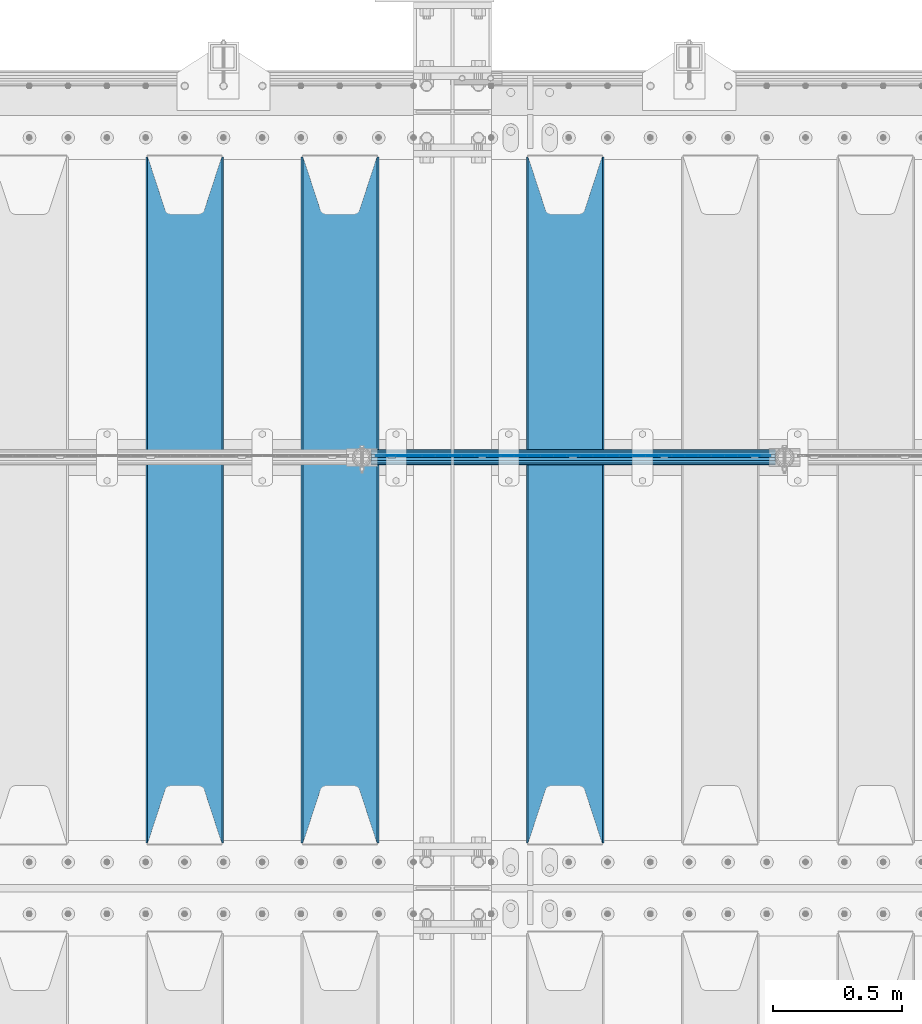
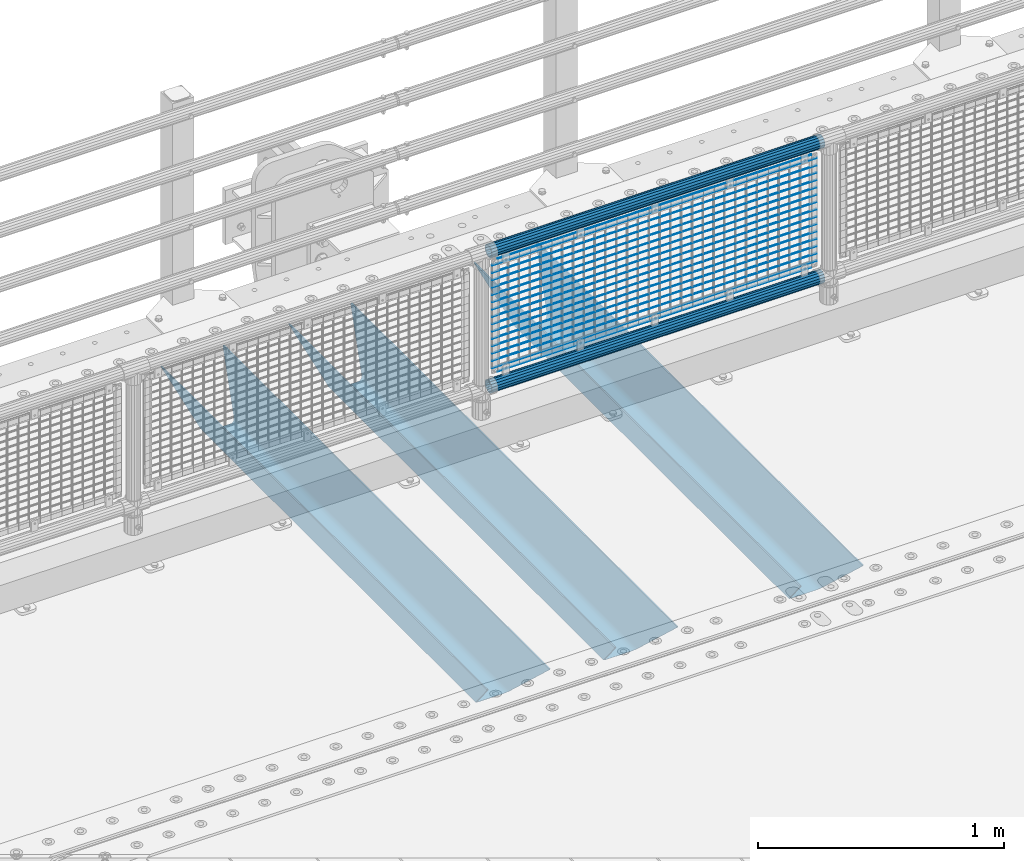
# One storey, part 137 of 270: 22 beams.
"""IFC2X3 building model written with IfcOpenShell, lengths in millimetres."""

import ifcopenshell
import ifcopenshell.guid

model = None  # the IFC model being written
_history = None  # IfcOwnerHistory: only IFC2X3 demands one
_inside = {}  # id of a spatial element -> (the spatial element, [elements in it])
_under = {}  # id of a project, library or spatial element -> (it, [spatial elements below it])
_declared = {}  # id of a project -> (the project, [libraries it declares])
_typed = {}  # id of a type object -> (the type object, [elements of that type])
_made_of = {}  # id of a material, layer set ... -> (it, [elements and type objects made of it])


def new_model(schema):
    """Start an empty IFC model of exactly this schema.

    Asked for "IFC4X3", IfcOpenShell would pick the latest addendum, in which some entities
    have other attributes; the version numbers below select the first issue.
    IFC2X3 requires an IfcOwnerHistory on every rooted entity: one is made here for all.
    """
    global model, _history
    if schema == "IFC4X3":
        model = ifcopenshell.file(schema_version=(4, 3, 0, 0))
    else:
        model = ifcopenshell.file(schema=schema)
    _inside.clear()
    _under.clear()
    _declared.clear()
    _typed.clear()
    _made_of.clear()
    _history = None
    if model.schema == "IFC2X3":
        org = make("IfcOrganization", Name="unknown")
        user = make(
            "IfcPersonAndOrganization",
            ThePerson=make("IfcPerson", FamilyName="unknown"),
            TheOrganization=org,
        )
        app = make(
            "IfcApplication",
            ApplicationDeveloper=org,
            Version="unknown",
            ApplicationFullName="unknown",
            ApplicationIdentifier="unknown",
        )
        _history = make(
            "IfcOwnerHistory",
            OwningUser=user,
            OwningApplication=app,
            ChangeAction="ADDED",
            CreationDate=0,
        )
    return model


def make(cls, **values):
    """One entity of the class cls with the attributes given. An attribute that is None is left unset."""
    return model.create_entity(
        cls, **{name: value for name, value in values.items() if value is not None}
    )


def rooted(cls, **values):
    """An entity with a GlobalId (a new one), such as an element, a storey or a relation."""
    return make(cls, GlobalId=ifcopenshell.guid.new(), OwnerHistory=_history, **values)


def si_unit(unit_type, name, prefix=None):
    """IfcSIUnit, for example si_unit("LENGTHUNIT", "METRE", prefix="MILLI")."""
    return make("IfcSIUnit", UnitType=unit_type, Prefix=prefix, Name=name)


def assignment(units):
    """IfcUnitAssignment: the units of a project."""
    return None if units is None else make("IfcUnitAssignment", Units=units)


def point(xyz):
    """IfcCartesianPoint."""
    return None if xyz is None else make("IfcCartesianPoint", Coordinates=xyz)


def direction(xyz):
    """IfcDirection."""
    return None if xyz is None else make("IfcDirection", DirectionRatios=xyz)


def frame(location, z_axis=None, x_axis=None):
    """IfcAxis2Placement3D, a coordinate frame: its origin and axes. An axis left out is left unset."""
    return make(
        "IfcAxis2Placement3D",
        Location=point(location),
        Axis=direction(z_axis),
        RefDirection=direction(x_axis),
    )


def origin_with_axes():
    """The frame at (0, 0, 0) with the z axis (0, 0, 1) and the x axis (1, 0, 0) written out."""
    return frame((0.0, 0.0, 0.0), z_axis=(0.0, 0.0, 1.0), x_axis=(1.0, 0.0, 0.0))


def place(relative_to, where):
    """IfcLocalPlacement: puts the frame where relative to a parent placement (None: the world)."""
    return make(
        "IfcLocalPlacement", PlacementRelTo=relative_to, RelativePlacement=where
    )


def context(
    kind, dimensions, precision=None, world=None, true_north=None, identifier=None
):
    """IfcGeometricRepresentationContext, for example the 3D "Model" context."""
    return make(
        "IfcGeometricRepresentationContext",
        ContextIdentifier=identifier,
        ContextType=kind,
        CoordinateSpaceDimension=dimensions,
        Precision=precision,
        WorldCoordinateSystem=world,
        TrueNorth=true_north,
    )


def subcontext(parent, identifier, kind, view, scale=None):
    """IfcGeometricRepresentationSubContext, for example "Body" below "Model"."""
    return make(
        "IfcGeometricRepresentationSubContext",
        ContextIdentifier=identifier,
        ContextType=kind,
        ParentContext=parent,
        TargetScale=scale,
        TargetView=view,
    )


def project(units=None, contexts=None):
    """IfcProject with its units and contexts."""
    return rooted(
        "IfcProject",
        Name="project",
        RepresentationContexts=contexts,
        UnitsInContext=assignment(units),
    )


def spatial(cls, under=None, at=None, **own):
    """A site, building, storey or space (cls), placed at a placement, below another one or the project."""
    s = rooted(cls, ObjectPlacement=at, **own)
    if under is not None:
        _under.setdefault(under.id(), (under, []))[1].append(s)
    return s


def faces_of(points, faces, orient=None, outer=None):
    """IfcFace entities. A face is a list of loops; a loop is a list of indices into points, from 0.

    orient and outer hold one flag for each loop. By default every Orientation is true, the
    first loop of a face is its IfcFaceOuterBound and the others are IfcFaceBound.
    """
    made = []
    for i, loops in enumerate(faces):
        bounds = []
        for j, loop in enumerate(loops):
            is_outer = j == 0 if outer is None else outer[i][j]
            bounds.append(
                make(
                    "IfcFaceOuterBound" if is_outer else "IfcFaceBound",
                    Bound=make("IfcPolyLoop", Polygon=[points[k] for k in loop]),
                    Orientation=True if orient is None else orient[i][j],
                )
            )
        made.append(make("IfcFace", Bounds=bounds))
    return made


def faceted_brep(points, faces, orient=None, outer=None, voids=None):
    """IfcFacetedBrep: a solid bounded by flat faces; with voids (closed shells), ...WithVoids."""
    shared = [point(p) for p in points]
    hull = make("IfcClosedShell", CfsFaces=faces_of(shared, faces, orient, outer))
    if voids is None:
        return make("IfcFacetedBrep", Outer=hull)
    return make(
        "IfcFacetedBrepWithVoids",
        Outer=hull,
        Voids=[
            make(cls, CfsFaces=faces_of(shared, fs, o, b)) for cls, fs, o, b in voids
        ],
    )


def shape(context_of_items, identifier, shape_type, items):
    """IfcShapeRepresentation: the items that make up one representation, for example the "Body"."""
    return make(
        "IfcShapeRepresentation",
        ContextOfItems=context_of_items,
        RepresentationIdentifier=identifier,
        RepresentationType=shape_type,
        Items=items,
    )


def material(Name=None, Category=None):
    """IfcMaterial."""
    return make("IfcMaterial", Name=Name, Category=Category)


def made_of(thing, what):
    """Note that an element or type object is made of a material, layer set ...; save() writes the relation."""
    if what is not None:
        _made_of.setdefault(what.id(), (what, []))[1].append(thing)
    return thing


def type_object(cls, material=None, **own):
    """A type object (cls), such as IfcWallType, which elements share."""
    return made_of(rooted(cls, **own), material)


def element(
    cls,
    number,
    at=None,
    inside=None,
    cuts=None,
    type_object=None,
    material=None,
    context=None,
    identifier="Body",
    shape_type=None,
    held_by="IfcProductDefinitionShape",
    body=None,
    shapes=None,
    **own,
):
    """One element of the class cls, such as IfcWall. Its Tag is "e" and its number.

    at: its placement. inside: the storey or other place that contains it. cuts: it is an
    opening in that element (IfcRelVoidsElement). A single representation is given by context,
    identifier, shape_type and body (its items); several are given by shapes. held_by: the class
    of the entity that holds the representations. save() writes the other relations.
    """
    e = rooted(cls, Tag="e%d" % number, ObjectPlacement=at, **own)
    if body is not None:
        shapes = [shape(context, identifier, shape_type, body)]
    if shapes is not None:
        e.Representation = make(held_by, Representations=shapes)
    if inside is not None:
        _inside.setdefault(inside.id(), (inside, []))[1].append(e)
    if cuts is not None:
        rooted(
            "IfcRelVoidsElement", RelatingBuildingElement=cuts, RelatedOpeningElement=e
        )
    if type_object is not None:
        _typed.setdefault(type_object.id(), (type_object, []))[1].append(e)
    return made_of(e, material)


def aggregate(whole, parts):
    """IfcRelAggregates: a whole, such as a stair, and the parts it consists of."""
    return rooted("IfcRelAggregates", RelatingObject=whole, RelatedObjects=parts)


def save(model, path):
    """Write the relations noted so far, then the file.

    IfcRelAggregates (storeys below a building ...), IfcRelContainedInSpatialStructure (elements
    in a storey), IfcRelDefinesByType, IfcRelAssociatesMaterial and IfcRelDeclares: one each for
    every whole, place, type object, material and project.
    """
    for whole, parts in _under.values():
        aggregate(whole, parts)
    for where, things in _inside.values():
        rooted(
            "IfcRelContainedInSpatialStructure",
            RelatedElements=things,
            RelatingStructure=where,
        )
    for kind, things in _typed.values():
        rooted("IfcRelDefinesByType", RelatedObjects=things, RelatingType=kind)
    for what, things in _made_of.values():
        rooted("IfcRelAssociatesMaterial", RelatedObjects=things, RelatingMaterial=what)
    for by, libraries in _declared.values():
        rooted("IfcRelDeclares", RelatingContext=by, RelatedDefinitions=libraries)
    model.write(path)


model = new_model("IFC2X3")

# Units and contexts
model_context = context("Model", 3, precision=1e-05, world=origin_with_axes())
body_context = subcontext(model_context, "Body", "Model", "MODEL_VIEW")
ifc_project = project(units=[si_unit("LENGTHUNIT", "METRE", prefix="MILLI"), si_unit("AREAUNIT", "SQUARE_METRE"), si_unit("VOLUMEUNIT", "CUBIC_METRE"), si_unit("MASSUNIT", "GRAM", prefix="KILO"), si_unit("TIMEUNIT", "SECOND"), si_unit("PLANEANGLEUNIT", "RADIAN"), si_unit("SOLIDANGLEUNIT", "STERADIAN"), si_unit("THERMODYNAMICTEMPERATUREUNIT", "DEGREE_CELSIUS"), si_unit("LUMINOUSINTENSITYUNIT", "LUMEN")], contexts=[model_context])

# Site, building, storey
site_placement = place(None, origin_with_axes())
site = spatial("IfcSite", under=ifc_project, at=site_placement, CompositionType="ELEMENT")
building_placement = place(site_placement, origin_with_axes())
building = spatial("IfcBuilding", under=site, at=building_placement, Name="Standard", CompositionType="ELEMENT")
storey_placement = place(building_placement, origin_with_axes())
storey = spatial("IfcBuildingStorey", under=building, at=storey_placement, Name="Undefined", CompositionType="ELEMENT", Elevation=0.0)

# Beams
ifc_material_1 = material(Name="STEEL/S355N")
beam_type_1 = type_object("IfcBeamType", PredefinedType="NOTDEFINED")
beam_1_placement = place(storey_placement, frame((14470.0, -17825.0, -115.0), z_axis=(0.0, 0.0, 1.0), x_axis=(0.0, 1.0, 0.0)))
element("IfcBeam", 1, at=beam_1_placement, inside=storey, type_object=beam_type_1, material=ifc_material_1, context=body_context, shape_type="Brep", body=[
    faceted_brep([(0.0, 150.0, 115.0), (0.0, 143.689999999999, 115.0), (2650.00000000297, 143.689999999999, 115.0), (2650.00000000297, 150.0, 115.0), (2650.00000000297, 142.059565218398, 110.000000003096), (2650.00000000297, 148.3695652184, 110.000000003096), (2441.90079219209, -80.1103600731112, -98.0992078077845), (2437.7588105432, -77.5672621345584, -102.241189456673), (2434.06523489747, -74.4080125315522, -105.934765102404), (2430.9108609509, -70.710272125576, -109.089139048974), (2428.37322971128, -66.5649389910068, -111.626770288588), (2426.51472138055, -62.0739139532889, -113.485278619323), (2425.38102192092, -57.3475956567672, -114.618978078955), (2424.99999999987, -52.5021667386536, -115.0), (2424.99999999987, 52.5021667386536, -115.0), (2425.38102192092, 57.3475956567672, -114.618978078955), (2426.51472138055, 62.0739139532889, -113.485278619323), (2428.37322971128, 66.5649389910068, -111.626770288588), (2430.9108609509, 70.710272125576, -109.089139048974), (2434.06523489747, 74.4080125315522, -105.934765102404), (2437.7588105432, 77.5672621345584, -102.241189456673), (2441.90079219209, 80.1103600731112, -98.0992078077846), (2446.38936140511, 81.9747917625791, -93.6106385947584), (2448.2494850041, 76.2713538057251, -91.7505149957729), (2444.62967112263, 74.76777986261, -95.3703288772456), (2441.28936334126, 72.7168944282894, -98.710636658607), (2438.31067330439, 70.1691124903846, -101.689326695487), (2435.76682334747, 67.1870637758839, -104.233176652398), (2433.72034654133, 63.8440531834895, -106.279653458539), (2432.22154950042, 60.222258798236, -107.778450499454), (2431.30727574265, 56.4107117849089, -108.692724257221), (2430.99999999987, 52.5031078186876, -109.0), (2430.99999999987, -52.5031078186876, -109.0), (2431.30727574265, -56.4107117849089, -108.692724257221), (2432.22154950042, -60.222258798236, -107.778450499454), (2433.72034654133, -63.8440531834895, -106.279653458539), (2435.76682334747, -67.1870637758839, -104.233176652398), (2438.31067330438, -70.1691124903846, -101.689326695487), (2441.28936334126, -72.7168944282894, -98.7106366586071), (2444.62967112263, -74.76777986261, -95.3703288772457), (2448.2494850041, -76.2713538057251, -91.7505149957729), (2650.00000000297, -142.059565218398, 110.000000003096), (2650.00000000297, -148.3695652184, 110.000000003096), (2446.38936140511, -81.9747917625791, -93.6106385947584), (2650.00000000297, -143.689999999999, 115.0), (2650.00000000297, -150.0, 115.0), (0.0, -143.689999999999, 115.0), (0.0, -150.0, 115.0), (0.0, -148.369565218261, 110.000000002672), (203.610638597431, -81.9747917625791, -93.6106385947584), (208.099207810457, -80.1103600731112, -98.0992078077845), (212.241189459342, -77.5672621345584, -102.241189456673), (215.934765105078, -74.4080125315522, -105.934765102404), (219.089139051644, -70.710272125576, -109.089139048974), (221.626770291259, -66.5649389910068, -111.626770288588), (223.485278621993, -62.0739139532889, -113.485278619323), (224.618978081628, -57.3475956567672, -114.618978078955), (225.00000000267, -52.5021667386536, -115.0), (225.00000000267, 52.5021667386536, -115.0), (224.618978081628, 57.3475956567672, -114.618978078955), (223.485278621993, 62.0739139532889, -113.485278619323), (221.626770291259, 66.5649389910068, -111.626770288588), (219.089139051644, 70.710272125576, -109.089139048974), (215.934765105078, 74.4080125315522, -105.934765102404), (212.241189459342, 77.5672621345584, -102.241189456673), (208.099207810457, 80.1103600731112, -98.0992078077846), (203.610638597431, 81.9747917625791, -93.6106385947584), (0.0, 148.369565218261, 110.000000002672), (0.0, 142.05956521826, 110.000000002672), (201.750514998446, 76.2713538057251, -91.7505149957729), (205.370328879915, 74.76777986261, -95.3703288772456), (208.710636661279, 72.7168944282894, -98.710636658607), (211.689326698157, 70.1691124903846, -101.689326695487), (214.233176655071, 67.1870637758839, -104.233176652398), (216.27965346121, 63.8440531834895, -106.279653458539), (217.778450502126, 60.222258798236, -107.778450499454), (218.692724259894, 56.4107117849089, -108.692724257221), (219.00000000267, 52.5031078186876, -109.0), (219.00000000267, -52.5031078186876, -109.0), (218.692724259894, -56.4107117849089, -108.692724257221), (217.778450502123, -60.222258798236, -107.778450499454), (216.27965346121, -63.8440531834895, -106.279653458539), (214.233176655071, -67.1870637758839, -104.233176652398), (211.689326698157, -70.1691124903846, -101.689326695487), (208.710636661279, -72.7168944282894, -98.7106366586071), (205.370328879915, -74.76777986261, -95.3703288772457), (201.750514998446, -76.2713538057251, -91.7505149957729), (0.0, -142.05956521826, 110.000000002672)], [[[0, 1, 2, 3]], [[3, 2, 4, 5]], [[6, 7, 8, 9, 10, 11, 12, 13, 14, 15, 16, 17, 18, 19, 20, 21, 22, 5, 4, 23, 24, 25, 26, 27, 28, 29, 30, 31, 32, 33, 34, 35, 36, 37, 38, 39, 40, 41, 42, 43]], [[44, 45, 42, 41]], [[46, 47, 45, 44]], [[43, 42, 45, 47, 48, 49]], [[6, 43, 49, 50]], [[7, 6, 50, 51]], [[8, 7, 51, 52]], [[9, 8, 52, 53]], [[10, 9, 53, 54]], [[11, 10, 54, 55]], [[12, 11, 55, 56]], [[13, 12, 56, 57]], [[14, 13, 57, 58]], [[15, 14, 58, 59]], [[16, 15, 59, 60]], [[17, 16, 60, 61]], [[18, 17, 61, 62]], [[19, 18, 62, 63]], [[20, 19, 63, 64]], [[21, 20, 64, 65]], [[22, 21, 65, 66]], [[0, 3, 5, 22, 66, 67]], [[1, 0, 67, 68]], [[23, 4, 2, 1, 68, 69]], [[24, 23, 69, 70]], [[25, 24, 70, 71]], [[26, 25, 71, 72]], [[27, 26, 72, 73]], [[28, 27, 73, 74]], [[29, 28, 74, 75]], [[30, 29, 75, 76]], [[31, 30, 76, 77]], [[32, 31, 77, 78]], [[33, 32, 78, 79]], [[34, 33, 79, 80]], [[35, 34, 80, 81]], [[36, 35, 81, 82]], [[37, 36, 82, 83]], [[38, 37, 83, 84]], [[39, 38, 84, 85]], [[40, 39, 85, 86]], [[46, 44, 41, 40, 86, 87]], [[47, 46, 87, 48]], [[86, 85, 84, 83, 82, 81, 80, 79, 78, 77, 76, 75, 74, 73, 72, 71, 70, 69, 68, 67, 66, 65, 64, 63, 62, 61, 60, 59, 58, 57, 56, 55, 54, 53, 52, 51, 50, 49, 48, 87]]]),
])
beam_2_placement = place(storey_placement, frame((13600.0, -17825.0, -115.0), z_axis=(0.0, 0.0, 1.0), x_axis=(0.0, 1.0, 0.0)))
element("IfcBeam", 2, at=beam_2_placement, inside=storey, type_object=beam_type_1, material=ifc_material_1, context=body_context, shape_type="Brep", body=[
    faceted_brep([(0.0, 150.0, 115.0), (0.0, 143.689999999999, 115.0), (2650.00000000297, 143.689999999999, 115.0), (2650.00000000297, 150.0, 115.0), (2650.00000000297, 142.059565218398, 110.000000003096), (2650.00000000297, 148.3695652184, 110.000000003096), (2441.90079219209, -80.1103600731112, -98.0992078077845), (2437.7588105432, -77.5672621345584, -102.241189456673), (2434.06523489747, -74.4080125315522, -105.934765102404), (2430.9108609509, -70.710272125576, -109.089139048974), (2428.37322971128, -66.5649389910068, -111.626770288588), (2426.51472138055, -62.0739139532889, -113.485278619323), (2425.38102192092, -57.3475956567672, -114.618978078955), (2424.99999999987, -52.5021667386536, -115.0), (2424.99999999987, 52.5021667386536, -115.0), (2425.38102192092, 57.3475956567672, -114.618978078955), (2426.51472138055, 62.0739139532889, -113.485278619323), (2428.37322971128, 66.5649389910068, -111.626770288588), (2430.9108609509, 70.710272125576, -109.089139048974), (2434.06523489747, 74.4080125315522, -105.934765102404), (2437.7588105432, 77.5672621345584, -102.241189456673), (2441.90079219209, 80.1103600731112, -98.0992078077846), (2446.38936140511, 81.9747917625791, -93.6106385947584), (2448.2494850041, 76.2713538057251, -91.7505149957729), (2444.62967112263, 74.76777986261, -95.3703288772456), (2441.28936334126, 72.7168944282894, -98.710636658607), (2438.31067330439, 70.1691124903846, -101.689326695487), (2435.76682334747, 67.1870637758839, -104.233176652398), (2433.72034654133, 63.8440531834895, -106.279653458539), (2432.22154950042, 60.222258798236, -107.778450499454), (2431.30727574265, 56.4107117849089, -108.692724257221), (2430.99999999987, 52.5031078186876, -109.0), (2430.99999999987, -52.5031078186876, -109.0), (2431.30727574265, -56.4107117849089, -108.692724257221), (2432.22154950042, -60.222258798236, -107.778450499454), (2433.72034654133, -63.8440531834895, -106.279653458539), (2435.76682334747, -67.1870637758839, -104.233176652398), (2438.31067330438, -70.1691124903846, -101.689326695487), (2441.28936334126, -72.7168944282894, -98.7106366586071), (2444.62967112263, -74.76777986261, -95.3703288772457), (2448.2494850041, -76.2713538057251, -91.7505149957729), (2650.00000000297, -142.059565218398, 110.000000003096), (2650.00000000297, -148.3695652184, 110.000000003096), (2446.38936140511, -81.9747917625791, -93.6106385947584), (2650.00000000297, -143.689999999999, 115.0), (2650.00000000297, -150.0, 115.0), (0.0, -143.689999999999, 115.0), (0.0, -150.0, 115.0), (0.0, -148.369565218261, 110.000000002672), (203.610638597431, -81.9747917625791, -93.6106385947584), (208.099207810457, -80.1103600731112, -98.0992078077845), (212.241189459342, -77.5672621345584, -102.241189456673), (215.934765105078, -74.4080125315522, -105.934765102404), (219.089139051644, -70.710272125576, -109.089139048974), (221.626770291259, -66.5649389910068, -111.626770288588), (223.485278621993, -62.0739139532889, -113.485278619323), (224.618978081628, -57.3475956567672, -114.618978078955), (225.00000000267, -52.5021667386536, -115.0), (225.00000000267, 52.5021667386536, -115.0), (224.618978081628, 57.3475956567672, -114.618978078955), (223.485278621993, 62.0739139532889, -113.485278619323), (221.626770291259, 66.5649389910068, -111.626770288588), (219.089139051644, 70.710272125576, -109.089139048974), (215.934765105078, 74.4080125315522, -105.934765102404), (212.241189459342, 77.5672621345584, -102.241189456673), (208.099207810457, 80.1103600731112, -98.0992078077846), (203.610638597431, 81.9747917625791, -93.6106385947584), (0.0, 148.369565218261, 110.000000002672), (0.0, 142.05956521826, 110.000000002672), (201.750514998446, 76.2713538057251, -91.7505149957729), (205.370328879915, 74.76777986261, -95.3703288772456), (208.710636661279, 72.7168944282894, -98.710636658607), (211.689326698157, 70.1691124903846, -101.689326695487), (214.233176655071, 67.1870637758839, -104.233176652398), (216.27965346121, 63.8440531834895, -106.279653458539), (217.778450502126, 60.222258798236, -107.778450499454), (218.692724259894, 56.4107117849089, -108.692724257221), (219.00000000267, 52.5031078186876, -109.0), (219.00000000267, -52.5031078186876, -109.0), (218.692724259894, -56.4107117849089, -108.692724257221), (217.778450502123, -60.222258798236, -107.778450499454), (216.27965346121, -63.8440531834895, -106.279653458539), (214.233176655071, -67.1870637758839, -104.233176652398), (211.689326698157, -70.1691124903846, -101.689326695487), (208.710636661279, -72.7168944282894, -98.7106366586071), (205.370328879915, -74.76777986261, -95.3703288772457), (201.750514998446, -76.2713538057251, -91.7505149957729), (0.0, -142.05956521826, 110.000000002672)], [[[0, 1, 2, 3]], [[3, 2, 4, 5]], [[6, 7, 8, 9, 10, 11, 12, 13, 14, 15, 16, 17, 18, 19, 20, 21, 22, 5, 4, 23, 24, 25, 26, 27, 28, 29, 30, 31, 32, 33, 34, 35, 36, 37, 38, 39, 40, 41, 42, 43]], [[44, 45, 42, 41]], [[46, 47, 45, 44]], [[43, 42, 45, 47, 48, 49]], [[6, 43, 49, 50]], [[7, 6, 50, 51]], [[8, 7, 51, 52]], [[9, 8, 52, 53]], [[10, 9, 53, 54]], [[11, 10, 54, 55]], [[12, 11, 55, 56]], [[13, 12, 56, 57]], [[14, 13, 57, 58]], [[15, 14, 58, 59]], [[16, 15, 59, 60]], [[17, 16, 60, 61]], [[18, 17, 61, 62]], [[19, 18, 62, 63]], [[20, 19, 63, 64]], [[21, 20, 64, 65]], [[22, 21, 65, 66]], [[0, 3, 5, 22, 66, 67]], [[1, 0, 67, 68]], [[23, 4, 2, 1, 68, 69]], [[24, 23, 69, 70]], [[25, 24, 70, 71]], [[26, 25, 71, 72]], [[27, 26, 72, 73]], [[28, 27, 73, 74]], [[29, 28, 74, 75]], [[30, 29, 75, 76]], [[31, 30, 76, 77]], [[32, 31, 77, 78]], [[33, 32, 78, 79]], [[34, 33, 79, 80]], [[35, 34, 80, 81]], [[36, 35, 81, 82]], [[37, 36, 82, 83]], [[38, 37, 83, 84]], [[39, 38, 84, 85]], [[40, 39, 85, 86]], [[46, 44, 41, 40, 86, 87]], [[47, 46, 87, 48]], [[86, 85, 84, 83, 82, 81, 80, 79, 78, 77, 76, 75, 74, 73, 72, 71, 70, 69, 68, 67, 66, 65, 64, 63, 62, 61, 60, 59, 58, 57, 56, 55, 54, 53, 52, 51, 50, 49, 48, 87]]]),
])
beam_3_placement = place(storey_placement, frame((13000.0, -17825.0, -115.0), z_axis=(0.0, 0.0, 1.0), x_axis=(0.0, 1.0, 0.0)))
element("IfcBeam", 3, at=beam_3_placement, inside=storey, type_object=beam_type_1, material=ifc_material_1, context=body_context, shape_type="Brep", body=[
    faceted_brep([(0.0, 150.0, 115.0), (0.0, 143.689999999999, 115.0), (2650.00000000297, 143.689999999999, 115.0), (2650.00000000297, 150.0, 115.0), (2650.00000000297, 142.059565218398, 110.000000003096), (2650.00000000297, 148.3695652184, 110.000000003096), (2441.90079219209, -80.1103600731112, -98.0992078077845), (2437.7588105432, -77.5672621345584, -102.241189456673), (2434.06523489747, -74.4080125315522, -105.934765102404), (2430.9108609509, -70.710272125576, -109.089139048974), (2428.37322971128, -66.5649389910068, -111.626770288588), (2426.51472138055, -62.0739139532889, -113.485278619323), (2425.38102192092, -57.3475956567672, -114.618978078955), (2424.99999999987, -52.5021667386536, -115.0), (2424.99999999987, 52.5021667386536, -115.0), (2425.38102192092, 57.3475956567672, -114.618978078955), (2426.51472138055, 62.0739139532889, -113.485278619323), (2428.37322971128, 66.5649389910068, -111.626770288588), (2430.9108609509, 70.710272125576, -109.089139048974), (2434.06523489747, 74.4080125315522, -105.934765102404), (2437.7588105432, 77.5672621345584, -102.241189456673), (2441.90079219209, 80.1103600731112, -98.0992078077846), (2446.38936140511, 81.9747917625791, -93.6106385947584), (2448.2494850041, 76.2713538057251, -91.7505149957729), (2444.62967112263, 74.76777986261, -95.3703288772456), (2441.28936334126, 72.7168944282894, -98.710636658607), (2438.31067330439, 70.1691124903846, -101.689326695487), (2435.76682334747, 67.1870637758839, -104.233176652398), (2433.72034654133, 63.8440531834895, -106.279653458539), (2432.22154950042, 60.222258798236, -107.778450499454), (2431.30727574265, 56.4107117849089, -108.692724257221), (2430.99999999987, 52.5031078186876, -109.0), (2430.99999999987, -52.5031078186876, -109.0), (2431.30727574265, -56.4107117849089, -108.692724257221), (2432.22154950042, -60.222258798236, -107.778450499454), (2433.72034654133, -63.8440531834895, -106.279653458539), (2435.76682334747, -67.1870637758839, -104.233176652398), (2438.31067330438, -70.1691124903846, -101.689326695487), (2441.28936334126, -72.7168944282894, -98.7106366586071), (2444.62967112263, -74.76777986261, -95.3703288772457), (2448.2494850041, -76.2713538057251, -91.7505149957729), (2650.00000000297, -142.059565218398, 110.000000003096), (2650.00000000297, -148.3695652184, 110.000000003096), (2446.38936140511, -81.9747917625791, -93.6106385947584), (2650.00000000297, -143.689999999999, 115.0), (2650.00000000297, -150.0, 115.0), (0.0, -143.689999999999, 115.0), (0.0, -150.0, 115.0), (0.0, -148.369565218261, 110.000000002672), (203.610638597431, -81.9747917625791, -93.6106385947584), (208.099207810457, -80.1103600731112, -98.0992078077845), (212.241189459342, -77.5672621345584, -102.241189456673), (215.934765105078, -74.4080125315522, -105.934765102404), (219.089139051644, -70.710272125576, -109.089139048974), (221.626770291259, -66.5649389910068, -111.626770288588), (223.485278621993, -62.0739139532889, -113.485278619323), (224.618978081628, -57.3475956567672, -114.618978078955), (225.00000000267, -52.5021667386536, -115.0), (225.00000000267, 52.5021667386536, -115.0), (224.618978081628, 57.3475956567672, -114.618978078955), (223.485278621993, 62.0739139532889, -113.485278619323), (221.626770291259, 66.5649389910068, -111.626770288588), (219.089139051644, 70.710272125576, -109.089139048974), (215.934765105078, 74.4080125315522, -105.934765102404), (212.241189459342, 77.5672621345584, -102.241189456673), (208.099207810457, 80.1103600731112, -98.0992078077846), (203.610638597431, 81.9747917625791, -93.6106385947584), (0.0, 148.369565218261, 110.000000002672), (0.0, 142.05956521826, 110.000000002672), (201.750514998446, 76.2713538057251, -91.7505149957729), (205.370328879915, 74.76777986261, -95.3703288772456), (208.710636661279, 72.7168944282894, -98.710636658607), (211.689326698157, 70.1691124903846, -101.689326695487), (214.233176655071, 67.1870637758839, -104.233176652398), (216.27965346121, 63.8440531834895, -106.279653458539), (217.778450502126, 60.222258798236, -107.778450499454), (218.692724259894, 56.4107117849089, -108.692724257221), (219.00000000267, 52.5031078186876, -109.0), (219.00000000267, -52.5031078186876, -109.0), (218.692724259894, -56.4107117849089, -108.692724257221), (217.778450502123, -60.222258798236, -107.778450499454), (216.27965346121, -63.8440531834895, -106.279653458539), (214.233176655071, -67.1870637758839, -104.233176652398), (211.689326698157, -70.1691124903846, -101.689326695487), (208.710636661279, -72.7168944282894, -98.7106366586071), (205.370328879915, -74.76777986261, -95.3703288772457), (201.750514998446, -76.2713538057251, -91.7505149957729), (0.0, -142.05956521826, 110.000000002672)], [[[0, 1, 2, 3]], [[3, 2, 4, 5]], [[6, 7, 8, 9, 10, 11, 12, 13, 14, 15, 16, 17, 18, 19, 20, 21, 22, 5, 4, 23, 24, 25, 26, 27, 28, 29, 30, 31, 32, 33, 34, 35, 36, 37, 38, 39, 40, 41, 42, 43]], [[44, 45, 42, 41]], [[46, 47, 45, 44]], [[43, 42, 45, 47, 48, 49]], [[6, 43, 49, 50]], [[7, 6, 50, 51]], [[8, 7, 51, 52]], [[9, 8, 52, 53]], [[10, 9, 53, 54]], [[11, 10, 54, 55]], [[12, 11, 55, 56]], [[13, 12, 56, 57]], [[14, 13, 57, 58]], [[15, 14, 58, 59]], [[16, 15, 59, 60]], [[17, 16, 60, 61]], [[18, 17, 61, 62]], [[19, 18, 62, 63]], [[20, 19, 63, 64]], [[21, 20, 64, 65]], [[22, 21, 65, 66]], [[0, 3, 5, 22, 66, 67]], [[1, 0, 67, 68]], [[23, 4, 2, 1, 68, 69]], [[24, 23, 69, 70]], [[25, 24, 70, 71]], [[26, 25, 71, 72]], [[27, 26, 72, 73]], [[28, 27, 73, 74]], [[29, 28, 74, 75]], [[30, 29, 75, 76]], [[31, 30, 76, 77]], [[32, 31, 77, 78]], [[33, 32, 78, 79]], [[34, 33, 79, 80]], [[35, 34, 80, 81]], [[36, 35, 81, 82]], [[37, 36, 82, 83]], [[38, 37, 83, 84]], [[39, 38, 84, 85]], [[40, 39, 85, 86]], [[46, 44, 41, 40, 86, 87]], [[47, 46, 87, 48]], [[86, 85, 84, 83, 82, 81, 80, 79, 78, 77, 76, 75, 74, 73, 72, 71, 70, 69, 68, 67, 66, 65, 64, 63, 62, 61, 60, 59, 58, 57, 56, 55, 54, 53, 52, 51, 50, 49, 48, 87]]]),
])
ifc_material_2 = material(Name="Misc_Undefined")
beam_type_2 = type_object("IfcBeamType", Name="D3", PredefinedType="NOTDEFINED")
for number, where, z_axis, x_axis in (
    (4, (13740.0, -16329.5, 851.596999999999), (0.0, 0.0, 1.0), (1.0, 0.0, 0.0)),
    (5, (13740.0, -16329.5, 669.452), (0.0, 0.0, 1.0), (1.0, 0.0, 0.0)),
    (6, (13740.0, -16329.5, 523.736), (0.0, 0.0, 1.0), (1.0, 0.0, 0.0)),
    (7, (13740.0, -16329.5, 487.307), (0.0, 0.0, 1.0), (1.0, 0.0, 0.0)),
    (8, (13740.0, -16329.5, 705.881), (0.0, 0.0, 1.0), (1.0, 0.0, 0.0)),
    (9, (13740.0, -16329.5, 596.594), (0.0, 0.0, 1.0), (1.0, 0.0, 0.0)),
    (10, (13740.0, -16329.5, 450.878), (0.0, 0.0, 1.0), (1.0, 0.0, 0.0)),
    (11, (13740.0, -16329.5, 815.167999999999), (0.0, 0.0, 1.0), (1.0, 0.0, 0.0)),
    (12, (13740.0, -16329.5, 888.025999999999), (0.0, 0.0, 1.0), (1.0, 0.0, 0.0)),
    (13, (13740.0, -16329.5, 778.738999999999), (0.0, 0.0, 1.0), (1.0, 0.0, 0.0)),
    (14, (13740.0, -16329.5, 742.309999999999), (0.0, 0.0, 1.0), (1.0, 0.0, 0.0)),
    (15, (13740.0, -16329.5, 633.023), (0.0, 0.0, 1.0), (1.0, 0.0, 0.0)),
    (16, (13740.0, -16329.5, 560.165), (0.0, 0.0, 1.0), (1.0, 0.0, 0.0)),
    (17, (13740.0, -16329.5, 414.449), (0.0, 0.0, 1.0), (1.0, 0.0, 0.0)),
):
    element("IfcBeam", number, at=place(storey_placement, frame(where, z_axis=z_axis, x_axis=x_axis)), inside=storey, type_object=beam_type_2, material=ifc_material_2, ObjectType="D3", context=body_context, shape_type="Brep", body=[
        faceted_brep([(0.0, -1.5, 0.0), (0.0, -0.75, -1.29903810567669), (1523.0, -0.75, -1.29903810567669), (1523.0, -1.5, 0.0), (0.0, 0.75, -1.29903810567669), (1523.0, 0.75, -1.29903810567669), (0.0, 1.5, 0.0), (1523.0, 1.5, 0.0), (0.0, 0.75, 1.29903810567669), (1523.0, 0.75, 1.29903810567669), (0.0, -0.75, 1.29903810567669), (1523.0, -0.75, 1.29903810567669)], [[[0, 1, 2, 3]], [[1, 4, 5, 2]], [[4, 6, 7, 5]], [[6, 8, 9, 7]], [[8, 10, 11, 9]], [[10, 0, 3, 11]], [[5, 7, 9, 11, 3, 2]], [[10, 8, 6, 4, 1, 0]]]),
    ])
beam_4_placement = place(storey_placement, frame((13765.0, -16329.5, 353.02), z_axis=(0.0, 0.0, 1.0), x_axis=(1.0, 0.0, 0.0)))
element("IfcBeam", 18, at=beam_4_placement, inside=storey, type_object=beam_type_2, material=ifc_material_2, ObjectType="D3", context=body_context, shape_type="Brep", body=[
    faceted_brep([(0.0, -1.5, 0.0), (0.0, -0.75, -1.29903810567669), (1473.0, -0.75, -1.29903810567669), (1473.0, -1.5, 0.0), (0.0, 0.75, -1.29903810567669), (1473.0, 0.75, -1.29903810567663), (0.0, 1.5, 0.0), (1473.0, 1.5, 0.0), (0.0, 0.75, 1.29903810567669), (1473.0, 0.75, 1.29903810567669), (0.0, -0.75, 1.29903810567669), (1473.0, -0.75, 1.29903810567669)], [[[0, 1, 2, 3]], [[1, 4, 5, 2]], [[4, 6, 7, 5]], [[6, 8, 9, 7]], [[8, 10, 11, 9]], [[10, 0, 3, 11]], [[5, 7, 9, 11, 3, 2]], [[10, 8, 6, 4, 1, 0]]]),
])
beam_5_placement = place(storey_placement, frame((13740.0, -16329.5, 378.02), z_axis=(0.0, 0.0, 1.0), x_axis=(1.0, 0.0, 0.0)))
element("IfcBeam", 19, at=beam_5_placement, inside=storey, type_object=beam_type_2, material=ifc_material_2, ObjectType="D3", context=body_context, shape_type="Brep", body=[
    faceted_brep([(0.0, -1.5, 0.0), (0.0, -0.75, -1.29903810567669), (1523.0, -0.75, -1.29903810567669), (1523.0, -1.5, 0.0), (0.0, 0.75, -1.29903810567669), (1523.0, 0.75, -1.29903810567669), (0.0, 1.5, 0.0), (1523.0, 1.5, 0.0), (0.0, 0.75, 1.29903810567669), (1523.0, 0.75, 1.29903810567669), (0.0, -0.75, 1.29903810567669), (1523.0, -0.75, 1.29903810567669)], [[[0, 1, 2, 3]], [[1, 4, 5, 2]], [[4, 6, 7, 5]], [[6, 8, 9, 7]], [[8, 10, 11, 9]], [[10, 0, 3, 11]], [[5, 7, 9, 11, 3, 2]], [[10, 8, 6, 4, 1, 0]]]),
])
beam_6_placement = place(storey_placement, frame((13765.0, -16329.5, 913.02), z_axis=(0.0, 0.0, 1.0), x_axis=(1.0, 0.0, 0.0)))
element("IfcBeam", 20, at=beam_6_placement, inside=storey, type_object=beam_type_2, material=ifc_material_2, ObjectType="D3", context=body_context, shape_type="Brep", body=[
    faceted_brep([(0.0, -1.5, 0.0), (0.0, -0.75, -1.29903810567669), (1473.0, -0.75, -1.29903810567669), (1473.0, -1.5, 0.0), (0.0, 0.75, -1.29903810567669), (1473.0, 0.75, -1.29903810567663), (0.0, 1.5, 0.0), (1473.0, 1.5, 0.0), (0.0, 0.75, 1.29903810567669), (1473.0, 0.75, 1.29903810567669), (0.0, -0.75, 1.29903810567669), (1473.0, -0.75, 1.29903810567669)], [[[0, 1, 2, 3]], [[1, 4, 5, 2]], [[4, 6, 7, 5]], [[6, 8, 9, 7]], [[8, 10, 11, 9]], [[10, 0, 3, 11]], [[5, 7, 9, 11, 3, 2]], [[10, 8, 6, 4, 1, 0]]]),
])
ifc_material_3 = material()
beam_type_3 = type_object("IfcBeamType", PredefinedType="NOTDEFINED")
beam_7_placement = place(storey_placement, frame((13719.85, -16335.5, 969.849999999999), z_axis=(0.0, 0.0, 1.0), x_axis=(1.0, 0.0, 0.0)))
element("IfcBeam", 21, at=beam_7_placement, inside=storey, type_object=beam_type_3, material=ifc_material_3, context=body_context, shape_type="Brep", body=[
    faceted_brep([(0.0, -25.3500000000004, 0.0), (0.0, -23.4203461491616, 9.70102501045403), (1563.0, -23.4203461491616, 9.70102501045506), (1563.0, -25.3500000000004, 0.0), (0.0, -17.9251569030785, 17.9251569030785), (1563.0, -17.9251569030785, 17.925156903079), (0.0, -9.70102501045585, 23.4203461491597), (1563.0, -9.70102501045585, 23.4203461491611), (0.0, 0.0, 25.3499999999985), (1563.0, 0.0, 25.35), (0.0, 9.70102501045585, 23.4203461491597), (1563.0, 9.70102501045585, 23.4203461491611), (0.0, 17.9251569030785, 17.9251569030785), (1563.0, 17.9251569030785, 17.925156903079), (0.0, 23.4203461491616, 9.70102501045403), (1563.0, 23.4203461491616, 9.70102501045506), (0.0, 25.3500000000004, 0.0), (1563.0, 25.3500000000004, 0.0), (0.0, 23.4203461491616, -9.70102501045403), (1563.0, 23.4203461491616, -9.70102501045506), (0.0, 17.9251569030785, -17.9251569030785), (1563.0, 17.9251569030785, -17.925156903079), (0.0, 9.70102501045585, -23.4203461491597), (1563.0, 9.70102501045585, -23.4203461491611), (0.0, 0.0, -25.3499999999985), (1563.0, 0.0, -25.35), (0.0, -9.70102501045585, -23.4203461491597), (1563.0, -9.70102501045585, -23.4203461491611), (0.0, -17.9251569030785, -17.9251569030785), (1563.0, -17.9251569030785, -17.925156903079), (0.0, -23.4203461491616, -9.70102501045403), (1563.0, -23.4203461491616, -9.70102501045506), (0.0, -30.1499999999996, 0.0), (0.0, -27.8549679052157, -11.5379054858058), (1563.0, -27.8549679052157, -11.5379054858075), (1563.0, -30.1499999999996, 0.0), (0.0, -21.3192694527752, -21.3192694527752), (1563.0, -21.3192694527752, -21.3192694527744), (0.0, -11.5379054858076, -27.8549679052157), (1563.0, -11.5379054858076, -27.8549679052153), (0.0, 0.0, -30.1500000000015), (1563.0, 0.0, -30.15), (0.0, 11.5379054858076, -27.8549679052157), (1563.0, 11.5379054858076, -27.8549679052153), (0.0, 21.3192694527752, -21.3192694527752), (1563.0, 21.3192694527752, -21.3192694527744), (0.0, 27.8549679052157, -11.5379054858058), (1563.0, 27.8549679052157, -11.5379054858074), (0.0, 30.1499999999996, 0.0), (1563.0, 30.1499999999996, 0.0), (0.0, 27.8549679052157, 11.5379054858058), (1563.0, 27.8549679052157, 11.5379054858074), (0.0, 21.3192694527752, 21.3192694527752), (1563.0, 21.3192694527752, 21.3192694527744), (0.0, 11.5379054858076, 27.8549679052157), (1563.0, 11.5379054858076, 27.8549679052153), (0.0, 0.0, 30.1500000000015), (1563.0, 0.0, 30.15), (0.0, -11.5379054858076, 27.8549679052157), (1563.0, -11.5379054858076, 27.8549679052153), (0.0, -21.3192694527752, 21.3192694527752), (1563.0, -21.3192694527752, 21.3192694527744), (0.0, -27.8549679052157, 11.5379054858058), (1563.0, -27.8549679052157, 11.5379054858074)], [[[0, 1, 2, 3]], [[1, 4, 5, 2]], [[4, 6, 7, 5]], [[6, 8, 9, 7]], [[8, 10, 11, 9]], [[10, 12, 13, 11]], [[12, 14, 15, 13]], [[14, 16, 17, 15]], [[16, 18, 19, 17]], [[18, 20, 21, 19]], [[20, 22, 23, 21]], [[22, 24, 25, 23]], [[24, 26, 27, 25]], [[26, 28, 29, 27]], [[28, 30, 31, 29]], [[30, 0, 3, 31]], [[32, 33, 34, 35]], [[33, 36, 37, 34]], [[36, 38, 39, 37]], [[38, 40, 41, 39]], [[40, 42, 43, 41]], [[42, 44, 45, 43]], [[44, 46, 47, 45]], [[46, 48, 49, 47]], [[48, 50, 51, 49]], [[50, 52, 53, 51]], [[52, 54, 55, 53]], [[54, 56, 57, 55]], [[56, 58, 59, 57]], [[58, 60, 61, 59]], [[60, 62, 63, 61]], [[62, 32, 35, 63]], [[37, 39, 41, 43, 45, 47, 49, 51, 53, 55, 57, 59, 61, 63, 35, 34], [5, 7, 9, 11, 13, 15, 17, 19, 21, 23, 25, 27, 29, 31, 3, 2]], [[62, 60, 58, 56, 54, 52, 50, 48, 46, 44, 42, 40, 38, 36, 33, 32], [30, 28, 26, 24, 22, 20, 18, 16, 14, 12, 10, 8, 6, 4, 1, 0]]]),
])
beam_8_placement = place(storey_placement, frame((13719.85, -16335.5, 298.170000000001), z_axis=(0.0, 0.0, 1.0), x_axis=(1.0, 0.0, 0.0)))
element("IfcBeam", 22, at=beam_8_placement, inside=storey, type_object=beam_type_3, material=ifc_material_3, context=body_context, shape_type="Brep", body=[
    faceted_brep([(0.0, -25.3500000000004, 0.0), (0.0, -23.4203461491616, 9.70102501045403), (1563.0, -23.4203461491616, 9.70102501045506), (1563.0, -25.3500000000004, 0.0), (0.0, -17.9251569030785, 17.9251569030785), (1563.0, -17.9251569030785, 17.925156903079), (0.0, -9.70102501045585, 23.4203461491597), (1563.0, -9.70102501045585, 23.4203461491611), (0.0, 0.0, 25.3499999999985), (1563.0, 0.0, 25.35), (0.0, 9.70102501045585, 23.4203461491597), (1563.0, 9.70102501045585, 23.4203461491611), (0.0, 17.9251569030785, 17.9251569030785), (1563.0, 17.9251569030785, 17.925156903079), (0.0, 23.4203461491616, 9.70102501045403), (1563.0, 23.4203461491616, 9.70102501045506), (0.0, 25.3500000000004, 0.0), (1563.0, 25.3500000000004, 0.0), (0.0, 23.4203461491616, -9.70102501045403), (1563.0, 23.4203461491616, -9.70102501045506), (0.0, 17.9251569030785, -17.9251569030785), (1563.0, 17.9251569030785, -17.925156903079), (0.0, 9.70102501045585, -23.4203461491597), (1563.0, 9.70102501045585, -23.4203461491611), (0.0, 0.0, -25.3499999999985), (1563.0, 0.0, -25.35), (0.0, -9.70102501045585, -23.4203461491597), (1563.0, -9.70102501045585, -23.4203461491611), (0.0, -17.9251569030785, -17.9251569030785), (1563.0, -17.9251569030785, -17.925156903079), (0.0, -23.4203461491616, -9.70102501045403), (1563.0, -23.4203461491616, -9.70102501045506), (0.0, -30.1499999999996, 0.0), (0.0, -27.8549679052157, -11.5379054858058), (1563.0, -27.8549679052157, -11.5379054858075), (1563.0, -30.1499999999996, 0.0), (0.0, -21.3192694527752, -21.3192694527752), (1563.0, -21.3192694527752, -21.3192694527744), (0.0, -11.5379054858076, -27.8549679052157), (1563.0, -11.5379054858076, -27.8549679052153), (0.0, 0.0, -30.1500000000015), (1563.0, 0.0, -30.15), (0.0, 11.5379054858076, -27.8549679052157), (1563.0, 11.5379054858076, -27.8549679052153), (0.0, 21.3192694527752, -21.3192694527752), (1563.0, 21.3192694527752, -21.3192694527744), (0.0, 27.8549679052157, -11.5379054858058), (1563.0, 27.8549679052157, -11.5379054858074), (0.0, 30.1499999999996, 0.0), (1563.0, 30.1499999999996, 0.0), (0.0, 27.8549679052157, 11.5379054858058), (1563.0, 27.8549679052157, 11.5379054858074), (0.0, 21.3192694527752, 21.3192694527752), (1563.0, 21.3192694527752, 21.3192694527744), (0.0, 11.5379054858076, 27.8549679052157), (1563.0, 11.5379054858076, 27.8549679052153), (0.0, 0.0, 30.1500000000015), (1563.0, 0.0, 30.15), (0.0, -11.5379054858076, 27.8549679052157), (1563.0, -11.5379054858076, 27.8549679052153), (0.0, -21.3192694527752, 21.3192694527752), (1563.0, -21.3192694527752, 21.3192694527744), (0.0, -27.8549679052157, 11.5379054858058), (1563.0, -27.8549679052157, 11.5379054858074)], [[[0, 1, 2, 3]], [[1, 4, 5, 2]], [[4, 6, 7, 5]], [[6, 8, 9, 7]], [[8, 10, 11, 9]], [[10, 12, 13, 11]], [[12, 14, 15, 13]], [[14, 16, 17, 15]], [[16, 18, 19, 17]], [[18, 20, 21, 19]], [[20, 22, 23, 21]], [[22, 24, 25, 23]], [[24, 26, 27, 25]], [[26, 28, 29, 27]], [[28, 30, 31, 29]], [[30, 0, 3, 31]], [[32, 33, 34, 35]], [[33, 36, 37, 34]], [[36, 38, 39, 37]], [[38, 40, 41, 39]], [[40, 42, 43, 41]], [[42, 44, 45, 43]], [[44, 46, 47, 45]], [[46, 48, 49, 47]], [[48, 50, 51, 49]], [[50, 52, 53, 51]], [[52, 54, 55, 53]], [[54, 56, 57, 55]], [[56, 58, 59, 57]], [[58, 60, 61, 59]], [[60, 62, 63, 61]], [[62, 32, 35, 63]], [[37, 39, 41, 43, 45, 47, 49, 51, 53, 55, 57, 59, 61, 63, 35, 34], [5, 7, 9, 11, 13, 15, 17, 19, 21, 23, 25, 27, 29, 31, 3, 2]], [[62, 60, 58, 56, 54, 52, 50, 48, 46, 44, 42, 40, 38, 36, 33, 32], [30, 28, 26, 24, 22, 20, 18, 16, 14, 12, 10, 8, 6, 4, 1, 0]]]),
])

save(model, "model.ifc")
